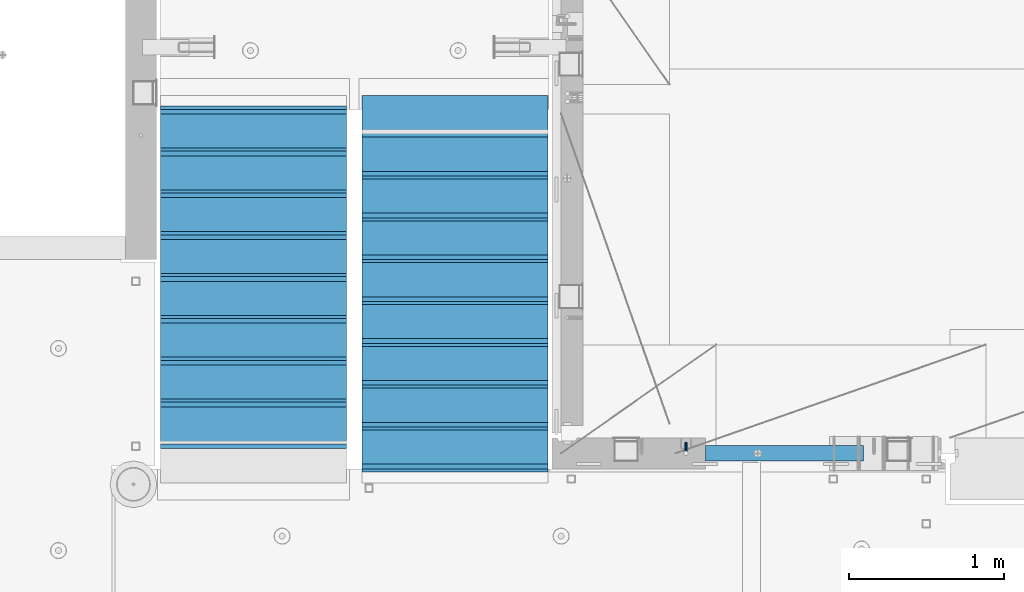
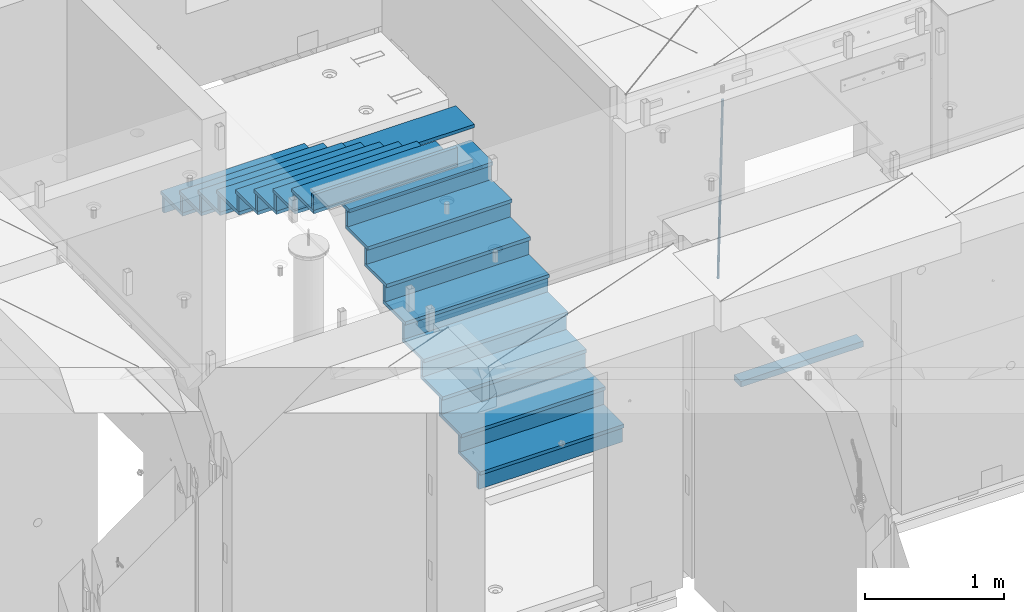
# One storey, part 118 of 352: 36 beams, 3 elements without a shape of their own.
"""IFC2X3 building model written with IfcOpenShell, lengths in millimetres."""

from ifc_helpers import new_model, si_unit, frame, origin_with_axes, place, context, subcontext, project, spatial, faceted_brep, material, type_object, element, aggregate, save


model = new_model("IFC2X3")

# Units and contexts
model_context = context("Model", 3, precision=1e-05, world=origin_with_axes())
body_context = subcontext(model_context, "Body", "Model", "MODEL_VIEW")
ifc_project = project(units=[si_unit("LENGTHUNIT", "METRE", prefix="MILLI"), si_unit("AREAUNIT", "SQUARE_METRE"), si_unit("VOLUMEUNIT", "CUBIC_METRE"), si_unit("MASSUNIT", "GRAM", prefix="KILO"), si_unit("TIMEUNIT", "SECOND"), si_unit("PLANEANGLEUNIT", "RADIAN"), si_unit("SOLIDANGLEUNIT", "STERADIAN"), si_unit("THERMODYNAMICTEMPERATUREUNIT", "DEGREE_CELSIUS"), si_unit("LUMINOUSINTENSITYUNIT", "LUMEN")], contexts=[model_context])

# Site, building, storey
site_placement = place(None, origin_with_axes())
site = spatial("IfcSite", under=ifc_project, at=site_placement, CompositionType="ELEMENT")
building_placement = place(site_placement, origin_with_axes())
building = spatial("IfcBuilding", under=site, at=building_placement, CompositionType="ELEMENT")
storey_placement = place(building_placement, origin_with_axes())
storey = spatial("IfcBuildingStorey", under=building, at=storey_placement, Name="6", CompositionType="ELEMENT", Elevation=0.0)

# Assembly, beams
assembly_1_placement = place(storey_placement, origin_with_axes())
assembly_1 = element("IfcElementAssembly", 1, at=assembly_1_placement, inside=storey, AssemblyPlace="NOTDEFINED", PredefinedType="REINFORCEMENT_UNIT")
ifc_material_1 = material()
beam_type_1 = type_object("IfcBeamType", Name="D20", PredefinedType="NOTDEFINED")
beam_1_placement = place(assembly_1_placement, frame((23075.0006866416, 17045.0000022791, 97790.0), z_axis=(0.00020576299992186, -0.999642804629538, -0.0267249099901004), x_axis=(-4.30000201928125e-08, -0.0267249099948059, 0.999642825806181)))
beam_1 = element("IfcBeam", 2, at=beam_1_placement, type_object=beam_type_1, material=ifc_material_1, Name="JM20", ObjectType="D20", context=body_context, shape_type="Brep", body=[
    faceted_brep([(0.0, -10.0, 0.0), (-4.19531716033816e-08, -7.07106781186667, -7.07106781187031), (60.4266690400545, -7.0710677960451, -7.07106780570757), (60.4266690441291, -9.99999998418934, 6.15546014159918e-09), (0.0, 0.0, -10.0), (60.426669036824, 1.58106558956206e-08, -9.99999999384454), (4.196772351861e-08, 7.07106781186303, -7.07106781186667), (60.4266690363438, 7.07106782768096, -7.07106780570757), (0.0, 10.0, 0.0), (60.4266690388904, 10.0000000158179, 6.15182216279209e-09), (4.196772351861e-08, 7.07106781185939, 7.07106781185939), (60.4266690429649, 7.07106782768096, 7.07106781802577), (0.0, 0.0, 10.0), (60.4266690461809, 1.58179318532348e-08, 10.0000000061555), (-4.19531716033816e-08, -7.07106781187031, 7.07106781185939), (60.4266690466611, -7.07106779605238, 7.07106781802213), (61.0378400410118, -7.07106779588503, -7.07106780564936), (60.991799419251, -9.99999998403655, 6.21366780251265e-09), (61.0569027789461, 1.5985278878361e-08, -9.99999999378269), (61.0378209396877, 7.07106782784831, -7.07106780564936), (60.9917724058905, 10.0000000159635, 6.21366780251265e-09), (60.9457317841297, 7.07106782781193, 7.0710678180767), (60.9266690461809, 1.59488990902901e-08, 10.0000000062028), (60.9457508854539, -7.07106779591413, 7.0710678180767), (61.6489592143771, -7.07106614513759, -7.06310863441468), (61.5568818710308, -9.9999984576425, 0.00735959856683621), (61.6870830769039, 1.71821739058942e-06, -9.99179257185824), (61.6489210170112, 7.07106947854481, -7.06310888312146), (61.556827851804, 10.0000015422847, 0.00735924683976918), (61.4647505084577, 7.07106922979438, 7.07782747982128), (61.4266266459163, 1.36643211590126e-06, 10.0065114172685), (61.464788705809, -7.07106639389531, 7.07782772852806), (176.543135720174, -7.07075579406956, -5.56673531796696), (176.451058376813, -9.99968810657447, 1.50373291501455), (176.581259582701, 0.000312069292704109, -8.49541925541052), (176.543097522794, 7.07137982961285, -5.56673556667374), (176.451004357587, 10.00031189336, 1.50373256329476), (176.35892701424, 7.07137958085514, 8.57420079627263), (176.320803151699, 0.000311717507429421, 11.5028847337162), (176.358965211621, -7.07075604281999, 8.57420104497578), (177.098753836006, -7.07075429323595, -5.55949898843028), (176.98362511232, -9.99968666800123, 1.510669025065), (177.146421932586, 0.000313595905026887, -8.48805862247536), (177.098706077581, 7.07138133041735, -5.55949936166144), (176.983557571715, 10.0003133318824, 1.51066849724157), (176.868428848029, 7.07138095712435, 8.58083651073321), (176.820760751449, 0.000313067976094317, 11.5093961447819), (176.868476606425, -7.07075466652896, 8.58083688396073), (177.654312950661, -7.07075204110879, -5.54863964998367), (177.516135294456, -9.99968450931192, 1.52107783331303), (177.711524267797, 0.000315886711177882, -8.47701274570863), (177.654255632195, 7.07138358250813, -5.54864021007961), (177.516054233929, 10.0003154905207, 1.5210770412159), (177.377876577739, 7.0713830223176, 8.59079452451624), (177.320665260588, 0.000315094497636892, 11.5191676202448), (177.377933896176, -7.07075260129932, 8.59079508461218), (299.580241614967, -7.07025777803938, -3.16539205229128), (299.442063958748, -9.99919024624614, 3.90432543100542), (299.637452932104, 0.000810149780591019, -6.09376514801625), (299.58018429653, 7.07187784557391, -3.16539261238358), (299.441982898265, 10.0008097535901, 3.90432463891557), (299.303805242045, 7.07187728538338, 10.974042122205), (299.246593924894, 0.00080935756341205, 13.9024152179336), (299.303862560482, -7.07025833822991, 10.9740426822973), (300.088882651282, -7.07025571611666, -3.15544980669438), (299.971788958996, -9.99918809853989, 3.91467979818117), (300.137357441272, 0.000812176291219657, -6.0839936725497), (300.088834180511, 7.07187990754028, -3.15545019384081), (299.971753863239, 10.0008119014747, 3.91467990454839), (299.854660170953, 7.07187951844026, 10.9848095094276), (299.806185380992, 0.000811626032373169, 13.9133533752902), (299.854708641738, -7.07025610520941, 10.9848098965813), (300.597573977022, -7.07025429077839, -3.14854421417112), (300.501599787152, -9.99918661431002, 3.92187219230618), (300.637311376035, 0.00081357714952901, -6.07720669196715), (300.597534354776, 7.07188133290401, -3.14854448120241), (300.501543752835, 10.0008133856099, 3.92187181466215), (300.40556956298, 7.07188106207104, 10.9922882211395), (300.365832163967, 0.000813194146758178, 13.9209506989318), (300.405609185211, -7.07025456160045, 10.9922884881707), (1494.60304651056, -7.06690872122999, 13.060333041718), (1494.50707232069, -9.99584104476162, 20.1307494481916), (1494.64278390956, 0.00415914670156781, 10.1316705639183), (1494.6030068883, 7.07522690244878, 13.0603327746867), (1494.50701628637, 10.004158955162, 20.1307490705476), (1494.4110420965, 7.07522663162308, 27.2011654770249), (1494.3713046975, 0.00415876370243495, 30.1298279548209), (1494.41108171875, -7.06690899205205, 27.2011657440526), (1495.1211563645, -7.06690726950183, 13.067366492749), (1495.00702625545, -9.99583964390331, 20.1375364287742), (1495.20660775043, 0.00416072652296862, 10.1393245920117), (1495.21332415029, 7.07522861253892, 13.0686179608165), (1495.13737118813, 10.0041607213934, 20.1393062718889), (1495.02324107911, 7.07522834699193, 27.2094762079141), (1494.93778969315, 0.00416035097441636, 30.1375181086514), (1494.93107329329, -7.06690753504881, 27.2082247398503), (1495.63922435709, -7.07365070849846, 13.0742491942874), (1495.5069397148, -10.00235861486, 20.1441724282631), (1495.77038591086, -0.00317370150150964, 10.1468279224828), (1495.82359171678, 7.06728286786529, 13.0767522910828), (1495.76767453534, 9.99594143344802, 20.1477123416917), (1495.63538989302, 7.0672335270865, 27.2176355756565), (1495.50422833927, -0.00324347991045215, 30.1450568474684), (1495.45102253335, -7.07370004928453, 27.2151324788683), (1517.48046966468, -7.35846502584536, 13.3649345949125), (1517.34818502239, -10.2871729322142, 20.4348578288809), (1517.61163121845, -0.287988018848409, 10.4375133231042), (1517.66483702436, 6.78246855052203, 13.3674376917079), (1517.60891984291, 9.71112711610476, 20.4383977423167), (1517.47663520063, 6.78241920973232, 27.5083209762815), (1517.34547364687, -0.288057797257352, 30.4357422480862), (1517.29226784095, -7.35851436663143, 27.5058178794898), (1518.11590717161, -7.36675126123009, 13.3733916404526), (1518.00827439407, -10.295780632965, 20.4436429663911), (1518.18994308249, -0.295529324139352, 10.4452100827657), (1518.18701289421, 6.77565927010801, 13.3743873367348), (1518.10883307132, 9.70460814510079, 20.4450510935785), (1518.00120029377, 6.77557877335857, 27.515302419517), (1517.9271643829, -0.295643163732166, 30.4434839772002), (1517.93009457119, -7.36683175797953, 27.5143067232275), (1518.75139849893, -7.36487536471395, 13.3816537936873), (1518.66841952164, -10.2938120781764, 20.4522328350286), (1518.76830418318, -0.293831718903675, 10.452712053142), (1518.7092334538, 6.77719739167878, 13.3811419616068), (1518.60878914295, 9.7060990139762, 20.4515089951637), (1518.52581016565, 6.77716230052101, 27.522088036505), (1518.50890448141, -0.293881345296541, 30.4510297770539), (1518.56797521077, -7.36491045587172, 27.5225998685855), (1618.77218426704, -7.06661321754655, 14.6790318180938), (1618.68920528975, -9.99554993101265, 21.7496108594387), (1618.78908995127, 0.0044304282637313, 11.7500900775485), (1618.73001922191, 7.07545953884255, 14.6785199860096), (1618.62957491104, 10.0043611611436, 21.748887019563), (1618.54659593375, 7.07542444768478, 28.8194660609042), (1618.52969024952, 0.00438080187086598, 31.7484078014531), (1618.58876097888, -7.06664830870795, 28.819977892992)], [[[0, 1, 2, 3]], [[1, 4, 5, 2]], [[4, 6, 7, 5]], [[6, 8, 9, 7]], [[8, 10, 11, 9]], [[10, 12, 13, 11]], [[12, 14, 15, 13]], [[14, 0, 3, 15]], [[14, 12, 10, 8, 6, 4, 1, 0]], [[3, 2, 16, 17]], [[2, 5, 18, 16]], [[5, 7, 19, 18]], [[7, 9, 20, 19]], [[9, 11, 21, 20]], [[11, 13, 22, 21]], [[13, 15, 23, 22]], [[15, 3, 17, 23]], [[17, 16, 24, 25]], [[16, 18, 26, 24]], [[18, 19, 27, 26]], [[19, 20, 28, 27]], [[20, 21, 29, 28]], [[21, 22, 30, 29]], [[22, 23, 31, 30]], [[23, 17, 25, 31]], [[25, 24, 32, 33]], [[24, 26, 34, 32]], [[26, 27, 35, 34]], [[27, 28, 36, 35]], [[28, 29, 37, 36]], [[29, 30, 38, 37]], [[30, 31, 39, 38]], [[31, 25, 33, 39]], [[33, 32, 40, 41]], [[32, 34, 42, 40]], [[34, 35, 43, 42]], [[35, 36, 44, 43]], [[36, 37, 45, 44]], [[37, 38, 46, 45]], [[38, 39, 47, 46]], [[39, 33, 41, 47]], [[41, 40, 48, 49]], [[40, 42, 50, 48]], [[42, 43, 51, 50]], [[43, 44, 52, 51]], [[44, 45, 53, 52]], [[45, 46, 54, 53]], [[46, 47, 55, 54]], [[47, 41, 49, 55]], [[49, 48, 56, 57]], [[48, 50, 58, 56]], [[50, 51, 59, 58]], [[51, 52, 60, 59]], [[52, 53, 61, 60]], [[53, 54, 62, 61]], [[54, 55, 63, 62]], [[55, 49, 57, 63]], [[57, 56, 64, 65]], [[56, 58, 66, 64]], [[58, 59, 67, 66]], [[59, 60, 68, 67]], [[60, 61, 69, 68]], [[61, 62, 70, 69]], [[62, 63, 71, 70]], [[63, 57, 65, 71]], [[65, 64, 72, 73]], [[64, 66, 74, 72]], [[66, 67, 75, 74]], [[67, 68, 76, 75]], [[68, 69, 77, 76]], [[69, 70, 78, 77]], [[70, 71, 79, 78]], [[71, 65, 73, 79]], [[73, 72, 80, 81]], [[72, 74, 82, 80]], [[74, 75, 83, 82]], [[75, 76, 84, 83]], [[76, 77, 85, 84]], [[77, 78, 86, 85]], [[78, 79, 87, 86]], [[79, 73, 81, 87]], [[81, 80, 88, 89]], [[80, 82, 90, 88]], [[82, 83, 91, 90]], [[83, 84, 92, 91]], [[84, 85, 93, 92]], [[85, 86, 94, 93]], [[86, 87, 95, 94]], [[87, 81, 89, 95]], [[89, 88, 96, 97]], [[88, 90, 98, 96]], [[90, 91, 99, 98]], [[91, 92, 100, 99]], [[92, 93, 101, 100]], [[93, 94, 102, 101]], [[94, 95, 103, 102]], [[95, 89, 97, 103]], [[97, 96, 104, 105]], [[96, 98, 106, 104]], [[98, 99, 107, 106]], [[99, 100, 108, 107]], [[100, 101, 109, 108]], [[101, 102, 110, 109]], [[102, 103, 111, 110]], [[103, 97, 105, 111]], [[105, 104, 112, 113]], [[104, 106, 114, 112]], [[106, 107, 115, 114]], [[107, 108, 116, 115]], [[108, 109, 117, 116]], [[109, 110, 118, 117]], [[110, 111, 119, 118]], [[111, 105, 113, 119]], [[113, 112, 120, 121]], [[112, 114, 122, 120]], [[114, 115, 123, 122]], [[115, 116, 124, 123]], [[116, 117, 125, 124]], [[117, 118, 126, 125]], [[118, 119, 127, 126]], [[119, 113, 121, 127]], [[121, 120, 128, 129]], [[120, 122, 130, 128]], [[122, 123, 131, 130]], [[123, 124, 132, 131]], [[124, 125, 133, 132]], [[125, 126, 134, 133]], [[126, 127, 135, 134]], [[127, 121, 129, 135]], [[130, 131, 132, 133, 134, 135, 129, 128]]]),
])
ifc_material_2 = material(Name="TIMBER/T24")
beam_type_2 = type_object("IfcBeamType", PredefinedType="NOTDEFINED")
beam_2_placement = place(assembly_1_placement, frame((23200.0006866455, 16980.0, 96880.0), z_axis=(0.0, 0.0, 1.0), x_axis=(1.0, 0.0, 0.0)))
beam_2 = element("IfcBeam", 3, at=beam_2_placement, type_object=beam_type_2, material=ifc_material_2, context=body_context, shape_type="Brep", body=[
    faceted_brep([(0.0, 50.0, -25.0), (0.0, 50.0, 25.0), (1020.0, 50.0, 25.0), (1020.0, 50.0, -25.0), (0.0, -50.0, 25.0), (1020.0, -50.0, 25.0), (0.0, -50.0, -25.0), (1020.0, -50.0, -25.0)], [[[0, 1, 2, 3]], [[1, 4, 5, 2]], [[4, 6, 7, 5]], [[6, 0, 3, 7]], [[5, 7, 3, 2]], [[6, 4, 1, 0]]]),
])
aggregate(assembly_1, [beam_1, beam_2])

assembly_2_placement = place(storey_placement, origin_with_axes())
assembly_2 = element("IfcElementAssembly", 4, at=assembly_2_placement, inside=storey, Name="E9", AssemblyPlace="NOTDEFINED", PredefinedType="NOTDEFINED")
ifc_material_3 = material(Name="Undefined/C32/40")
beam_type_3 = type_object("IfcBeamType", PredefinedType="NOTDEFINED")
beam_3_placement = place(assembly_2_placement, frame((20885.0002457424, 17024.9998138874, 99662.1), z_axis=(0.0, 1.0, 0.0), x_axis=(-1.0, 3.00000001838171e-08, 0.0)))
beam_3 = element("IfcBeam", 5, at=beam_3_placement, type_object=beam_type_3, material=ifc_material_3, Name="E9", context=body_context, shape_type="Brep", body=[
    faceted_brep([(0.0, 68.5, -15.0), (0.0, 68.5, 15.0), (1200.0, 68.5, 15.0), (1200.0, 68.5, -15.0), (0.0, -68.5, 15.0), (1200.0, -68.5, 15.0), (0.0, -68.5, -15.0), (1200.0, -68.5, -15.0)], [[[0, 1, 2, 3]], [[1, 4, 5, 2]], [[4, 6, 7, 5]], [[6, 0, 3, 7]], [[5, 7, 3, 2]], [[6, 4, 1, 0]]]),
])
beam_4_placement = place(assembly_2_placement, frame((20885.0002457424, 17294.9998138874, 99495.4), z_axis=(0.0, 1.0, 0.0), x_axis=(-1.0, 3.00000001838171e-08, 0.0)))
beam_4 = element("IfcBeam", 6, at=beam_4_placement, type_object=beam_type_3, material=ifc_material_3, Name="E9", context=body_context, shape_type="Brep", body=[
    faceted_brep([(0.0, 68.5, -15.0), (0.0, 68.5, 15.0), (1200.0, 68.5, 15.0), (1200.0, 68.5, -15.0), (0.0, -68.5, 15.0), (1200.0, -68.5, 15.0), (0.0, -68.5, -15.0), (1200.0, -68.5, -15.0)], [[[0, 1, 2, 3]], [[1, 4, 5, 2]], [[4, 6, 7, 5]], [[6, 0, 3, 7]], [[5, 7, 3, 2]], [[6, 4, 1, 0]]]),
])
beam_5_placement = place(assembly_2_placement, frame((20885.0002457424, 17564.9998138874, 99328.7), z_axis=(0.0, 1.0, 0.0), x_axis=(-1.0, 3.00000001838171e-08, 0.0)))
beam_5 = element("IfcBeam", 7, at=beam_5_placement, type_object=beam_type_3, material=ifc_material_3, Name="E9", context=body_context, shape_type="Brep", body=[
    faceted_brep([(0.0, 68.5, -15.0), (0.0, 68.5, 15.0), (1200.0, 68.5, 15.0), (1200.0, 68.5, -15.0), (0.0, -68.5, 15.0), (1200.0, -68.5, 15.0), (0.0, -68.5, -15.0), (1200.0, -68.5, -15.0)], [[[0, 1, 2, 3]], [[1, 4, 5, 2]], [[4, 6, 7, 5]], [[6, 0, 3, 7]], [[5, 7, 3, 2]], [[6, 4, 1, 0]]]),
])
beam_6_placement = place(assembly_2_placement, frame((20885.0002457424, 17834.9998138874, 99162.0), z_axis=(0.0, 1.0, 0.0), x_axis=(-1.0, 3.00000001838171e-08, 0.0)))
beam_6 = element("IfcBeam", 8, at=beam_6_placement, type_object=beam_type_3, material=ifc_material_3, Name="E9", context=body_context, shape_type="Brep", body=[
    faceted_brep([(0.0, 68.5, -15.0), (0.0, 68.5, 15.0), (1200.0, 68.5, 15.0), (1200.0, 68.5, -15.0), (0.0, -68.5, 15.0), (1200.0, -68.5, 15.0), (0.0, -68.5, -15.0), (1200.0, -68.5, -15.0)], [[[0, 1, 2, 3]], [[1, 4, 5, 2]], [[4, 6, 7, 5]], [[6, 0, 3, 7]], [[5, 7, 3, 2]], [[6, 4, 1, 0]]]),
])
beam_7_placement = place(assembly_2_placement, frame((20885.0002457424, 18104.9998138874, 98995.3), z_axis=(0.0, 1.0, 0.0), x_axis=(-1.0, 3.00000001838171e-08, 0.0)))
beam_7 = element("IfcBeam", 9, at=beam_7_placement, type_object=beam_type_3, material=ifc_material_3, Name="E9", context=body_context, shape_type="Brep", body=[
    faceted_brep([(0.0, 68.5, -15.0), (0.0, 68.5, 15.0), (1200.0, 68.5, 15.0), (1200.0, 68.5, -15.0), (0.0, -68.5, 15.0), (1200.0, -68.5, 15.0), (0.0, -68.5, -15.0), (1200.0, -68.5, -15.0)], [[[0, 1, 2, 3]], [[1, 4, 5, 2]], [[4, 6, 7, 5]], [[6, 0, 3, 7]], [[5, 7, 3, 2]], [[6, 4, 1, 0]]]),
])
beam_8_placement = place(assembly_2_placement, frame((20885.0002457424, 18374.9998138874, 98828.6), z_axis=(0.0, 1.0, 0.0), x_axis=(-1.0, 3.00000001838171e-08, 0.0)))
beam_8 = element("IfcBeam", 10, at=beam_8_placement, type_object=beam_type_3, material=ifc_material_3, Name="E9", context=body_context, shape_type="Brep", body=[
    faceted_brep([(0.0, 68.5, -15.0), (0.0, 68.5, 15.0), (1200.0, 68.5, 15.0), (1200.0, 68.5, -15.0), (0.0, -68.5, 15.0), (1200.0, -68.5, 15.0), (0.0, -68.5, -15.0), (1200.0, -68.5, -15.0)], [[[0, 1, 2, 3]], [[1, 4, 5, 2]], [[4, 6, 7, 5]], [[6, 0, 3, 7]], [[5, 7, 3, 2]], [[6, 4, 1, 0]]]),
])
beam_9_placement = place(assembly_2_placement, frame((20885.0002457424, 18644.9998138874, 98661.9), z_axis=(0.0, 1.0, 0.0), x_axis=(-1.0, 3.00000001838171e-08, 0.0)))
beam_9 = element("IfcBeam", 11, at=beam_9_placement, type_object=beam_type_3, material=ifc_material_3, Name="E9", context=body_context, shape_type="Brep", body=[
    faceted_brep([(0.0, 68.5, -15.0), (0.0, 68.5, 15.0), (1200.0, 68.5, 15.0), (1200.0, 68.5, -15.0), (0.0, -68.5, 15.0), (1200.0, -68.5, 15.0), (0.0, -68.5, -15.0), (1200.0, -68.5, -15.0)], [[[0, 1, 2, 3]], [[1, 4, 5, 2]], [[4, 6, 7, 5]], [[6, 0, 3, 7]], [[5, 7, 3, 2]], [[6, 4, 1, 0]]]),
])
beam_10_placement = place(assembly_2_placement, frame((20885.0002457424, 18914.9998138874, 98495.2), z_axis=(0.0, 1.0, 0.0), x_axis=(-1.0, 3.00000001838171e-08, 0.0)))
beam_10 = element("IfcBeam", 12, at=beam_10_placement, type_object=beam_type_3, material=ifc_material_3, Name="E9", context=body_context, shape_type="Brep", body=[
    faceted_brep([(0.0, 68.5, -15.0), (0.0, 68.5, 15.0), (1200.0, 68.5, 15.0), (1200.0, 68.5, -15.0), (0.0, -68.5, 15.0), (1200.0, -68.5, 15.0), (0.0, -68.5, -15.0), (1200.0, -68.5, -15.0)], [[[0, 1, 2, 3]], [[1, 4, 5, 2]], [[4, 6, 7, 5]], [[6, 0, 3, 7]], [[5, 7, 3, 2]], [[6, 4, 1, 0]]]),
])
beam_11_placement = place(assembly_2_placement, frame((20885.0002457424, 19184.9998138874, 98328.5), z_axis=(0.0, 1.0, 0.0), x_axis=(-1.0, 3.00000001838171e-08, 0.0)))
beam_11 = element("IfcBeam", 13, at=beam_11_placement, type_object=beam_type_3, material=ifc_material_3, Name="E9", context=body_context, shape_type="Brep", body=[
    faceted_brep([(0.0, 68.5, -15.0), (0.0, 68.5, 15.0), (1200.0, 68.5, 15.0), (1200.0, 68.5, -15.0), (0.0, -68.5, 15.0), (1200.0, -68.5, 15.0), (0.0, -68.5, -15.0), (1200.0, -68.5, -15.0)], [[[0, 1, 2, 3]], [[1, 4, 5, 2]], [[4, 6, 7, 5]], [[6, 0, 3, 7]], [[5, 7, 3, 2]], [[6, 4, 1, 0]]]),
])

assembly_3_placement = place(storey_placement, origin_with_axes())
assembly_3 = element("IfcElementAssembly", 14, at=assembly_3_placement, inside=storey, Name="E9", AssemblyPlace="NOTDEFINED", PredefinedType="NOTDEFINED")
beam_12_placement = place(assembly_3_placement, frame((20985.002175553, 18785.001025346, 97995.1036072969), z_axis=(0.0, -1.0, 0.0), x_axis=(1.0, 0.0, 0.0)))
beam_12 = element("IfcBeam", 15, at=beam_12_placement, type_object=beam_type_3, material=ifc_material_3, Name="E9", context=body_context, shape_type="Brep", body=[
    faceted_brep([(0.0, 68.5, -15.0), (0.0, 68.5, 15.0), (1200.0, 68.5, 15.0), (1200.0, 68.5, -15.0), (0.0, -68.5, 15.0), (1200.0, -68.5, 15.0), (0.0, -68.5, -15.0), (1200.0, -68.5, -15.0)], [[[0, 1, 2, 3]], [[1, 4, 5, 2]], [[4, 6, 7, 5]], [[6, 0, 3, 7]], [[5, 7, 3, 2]], [[6, 4, 1, 0]]]),
])
beam_13_placement = place(assembly_3_placement, frame((20985.002175553, 18515.001025346, 97828.4036072969), z_axis=(0.0, -1.0, 0.0), x_axis=(1.0, 0.0, 0.0)))
beam_13 = element("IfcBeam", 16, at=beam_13_placement, type_object=beam_type_3, material=ifc_material_3, Name="E9", context=body_context, shape_type="Brep", body=[
    faceted_brep([(0.0, 68.5, -15.0), (0.0, 68.5, 15.0), (1200.0, 68.5, 15.0), (1200.0, 68.5, -15.0), (0.0, -68.5, 15.0), (1200.0, -68.5, 15.0), (0.0, -68.5, -15.0), (1200.0, -68.5, -15.0)], [[[0, 1, 2, 3]], [[1, 4, 5, 2]], [[4, 6, 7, 5]], [[6, 0, 3, 7]], [[5, 7, 3, 2]], [[6, 4, 1, 0]]]),
])
beam_14_placement = place(assembly_3_placement, frame((20985.002175553, 18245.001025346, 97661.7036072969), z_axis=(0.0, -1.0, 0.0), x_axis=(1.0, 0.0, 0.0)))
beam_14 = element("IfcBeam", 17, at=beam_14_placement, type_object=beam_type_3, material=ifc_material_3, Name="E9", context=body_context, shape_type="Brep", body=[
    faceted_brep([(0.0, 68.5, -15.0), (0.0, 68.5, 15.0), (1200.0, 68.5, 15.0), (1200.0, 68.5, -15.0), (0.0, -68.5, 15.0), (1200.0, -68.5, 15.0), (0.0, -68.5, -15.0), (1200.0, -68.5, -15.0)], [[[0, 1, 2, 3]], [[1, 4, 5, 2]], [[4, 6, 7, 5]], [[6, 0, 3, 7]], [[5, 7, 3, 2]], [[6, 4, 1, 0]]]),
])
beam_15_placement = place(assembly_3_placement, frame((20985.002175553, 17975.001025346, 97495.0036072969), z_axis=(0.0, -1.0, 0.0), x_axis=(1.0, 0.0, 0.0)))
beam_15 = element("IfcBeam", 18, at=beam_15_placement, type_object=beam_type_3, material=ifc_material_3, Name="E9", context=body_context, shape_type="Brep", body=[
    faceted_brep([(0.0, 68.5, -15.0), (0.0, 68.5, 15.0), (1200.0, 68.5, 15.0), (1200.0, 68.5, -15.0), (0.0, -68.5, 15.0), (1200.0, -68.5, 15.0), (0.0, -68.5, -15.0), (1200.0, -68.5, -15.0)], [[[0, 1, 2, 3]], [[1, 4, 5, 2]], [[4, 6, 7, 5]], [[6, 0, 3, 7]], [[5, 7, 3, 2]], [[6, 4, 1, 0]]]),
])
beam_16_placement = place(assembly_3_placement, frame((20985.002175553, 17705.001025346, 97328.3036072969), z_axis=(0.0, -1.0, 0.0), x_axis=(1.0, 0.0, 0.0)))
beam_16 = element("IfcBeam", 19, at=beam_16_placement, type_object=beam_type_3, material=ifc_material_3, Name="E9", context=body_context, shape_type="Brep", body=[
    faceted_brep([(0.0, 68.5, -15.0), (0.0, 68.5, 15.0), (1200.0, 68.5, 15.0), (1200.0, 68.5, -15.0), (0.0, -68.5, 15.0), (1200.0, -68.5, 15.0), (0.0, -68.5, -15.0), (1200.0, -68.5, -15.0)], [[[0, 1, 2, 3]], [[1, 4, 5, 2]], [[4, 6, 7, 5]], [[6, 0, 3, 7]], [[5, 7, 3, 2]], [[6, 4, 1, 0]]]),
])
beam_17_placement = place(assembly_3_placement, frame((20985.002175553, 17435.001025346, 97161.6036072969), z_axis=(0.0, -1.0, 0.0), x_axis=(1.0, 0.0, 0.0)))
beam_17 = element("IfcBeam", 20, at=beam_17_placement, type_object=beam_type_3, material=ifc_material_3, Name="E9", context=body_context, shape_type="Brep", body=[
    faceted_brep([(0.0, 68.5, -15.0), (0.0, 68.5, 15.0), (1200.0, 68.5, 15.0), (1200.0, 68.5, -15.0), (0.0, -68.5, 15.0), (1200.0, -68.5, 15.0), (0.0, -68.5, -15.0), (1200.0, -68.5, -15.0)], [[[0, 1, 2, 3]], [[1, 4, 5, 2]], [[4, 6, 7, 5]], [[6, 0, 3, 7]], [[5, 7, 3, 2]], [[6, 4, 1, 0]]]),
])
beam_18_placement = place(assembly_3_placement, frame((20985.002175553, 17165.001025346, 96994.9036072969), z_axis=(0.0, -1.0, 0.0), x_axis=(1.0, 0.0, 0.0)))
beam_18 = element("IfcBeam", 21, at=beam_18_placement, type_object=beam_type_3, material=ifc_material_3, Name="E9", context=body_context, shape_type="Brep", body=[
    faceted_brep([(0.0, 68.5, -15.0), (0.0, 68.5, 15.0), (1200.0, 68.5, 15.0), (1200.0, 68.5, -15.0), (0.0, -68.5, 15.0), (1200.0, -68.5, 15.0), (0.0, -68.5, -15.0), (1200.0, -68.5, -15.0)], [[[0, 1, 2, 3]], [[1, 4, 5, 2]], [[4, 6, 7, 5]], [[6, 0, 3, 7]], [[5, 7, 3, 2]], [[6, 4, 1, 0]]]),
])
beam_19_placement = place(assembly_3_placement, frame((20985.002175553, 16895.001025346, 96828.2036072969), z_axis=(0.0, -1.0, 0.0), x_axis=(1.0, 0.0, 0.0)))
beam_19 = element("IfcBeam", 22, at=beam_19_placement, type_object=beam_type_3, material=ifc_material_3, Name="E9", context=body_context, shape_type="Brep", body=[
    faceted_brep([(0.0, 68.5, -15.0), (0.0, 68.5, 15.0), (1200.0, 68.5, 15.0), (1200.0, 68.5, -15.0), (0.0, -68.5, 15.0), (1200.0, -68.5, 15.0), (0.0, -68.5, -15.0), (1200.0, -68.5, -15.0)], [[[0, 1, 2, 3]], [[1, 4, 5, 2]], [[4, 6, 7, 5]], [[6, 0, 3, 7]], [[5, 7, 3, 2]], [[6, 4, 1, 0]]]),
])

# Beam
beam_type_4 = type_object("IfcBeamType", PredefinedType="NOTDEFINED")
beam_20_placement = place(assembly_2_placement, frame((20885.0002457424, 17169.9998138874, 99578.6), z_axis=(0.0, 1.0, 0.0), x_axis=(-1.0, 3.00000001838171e-08, 0.0)))
beam_20 = element("IfcBeam", 23, at=beam_20_placement, type_object=beam_type_4, material=ifc_material_3, Name="E9", context=body_context, shape_type="Brep", body=[
    faceted_brep([(0.0, 15.0, -160.0), (0.0, 15.0, 160.0), (1200.0, 15.0, 160.0), (1200.0, 15.0, -160.0), (0.0, -15.0, 160.0), (1200.0, -15.0, 160.0), (0.0, -15.0, -160.0), (1200.0, -15.0, -160.0)], [[[0, 1, 2, 3]], [[1, 4, 5, 2]], [[4, 6, 7, 5]], [[6, 0, 3, 7]], [[5, 7, 3, 2]], [[6, 4, 1, 0]]]),
])

beam_21_placement = place(assembly_2_placement, frame((20885.0002457424, 17439.9998138874, 99411.9), z_axis=(0.0, 1.0, 0.0), x_axis=(-1.0, 3.00000001838171e-08, 0.0)))
beam_21 = element("IfcBeam", 24, at=beam_21_placement, type_object=beam_type_4, material=ifc_material_3, Name="E9", context=body_context, shape_type="Brep", body=[
    faceted_brep([(0.0, 15.0, -160.0), (0.0, 15.0, 160.0), (1200.0, 15.0, 160.0), (1200.0, 15.0, -160.0), (0.0, -15.0, 160.0), (1200.0, -15.0, 160.0), (0.0, -15.0, -160.0), (1200.0, -15.0, -160.0)], [[[0, 1, 2, 3]], [[1, 4, 5, 2]], [[4, 6, 7, 5]], [[6, 0, 3, 7]], [[5, 7, 3, 2]], [[6, 4, 1, 0]]]),
])

beam_22_placement = place(assembly_2_placement, frame((20885.0002457424, 17709.9998138874, 99245.2), z_axis=(0.0, 1.0, 0.0), x_axis=(-1.0, 3.00000001838171e-08, 0.0)))
beam_22 = element("IfcBeam", 25, at=beam_22_placement, type_object=beam_type_4, material=ifc_material_3, Name="E9", context=body_context, shape_type="Brep", body=[
    faceted_brep([(0.0, 15.0, -160.0), (0.0, 15.0, 160.0), (1200.0, 15.0, 160.0), (1200.0, 15.0, -160.0), (0.0, -15.0, 160.0), (1200.0, -15.0, 160.0), (0.0, -15.0, -160.0), (1200.0, -15.0, -160.0)], [[[0, 1, 2, 3]], [[1, 4, 5, 2]], [[4, 6, 7, 5]], [[6, 0, 3, 7]], [[5, 7, 3, 2]], [[6, 4, 1, 0]]]),
])

beam_23_placement = place(assembly_2_placement, frame((20885.0002457424, 17979.9998138874, 99078.5), z_axis=(0.0, 1.0, 0.0), x_axis=(-1.0, 3.00000001838171e-08, 0.0)))
beam_23 = element("IfcBeam", 26, at=beam_23_placement, type_object=beam_type_4, material=ifc_material_3, Name="E9", context=body_context, shape_type="Brep", body=[
    faceted_brep([(0.0, 15.0, -160.0), (0.0, 15.0, 160.0), (1200.0, 15.0, 160.0), (1200.0, 15.0, -160.0), (0.0, -15.0, 160.0), (1200.0, -15.0, 160.0), (0.0, -15.0, -160.0), (1200.0, -15.0, -160.0)], [[[0, 1, 2, 3]], [[1, 4, 5, 2]], [[4, 6, 7, 5]], [[6, 0, 3, 7]], [[5, 7, 3, 2]], [[6, 4, 1, 0]]]),
])

beam_24_placement = place(assembly_2_placement, frame((20885.0002457424, 18249.9998138874, 98911.8), z_axis=(0.0, 1.0, 0.0), x_axis=(-1.0, 3.00000001838171e-08, 0.0)))
beam_24 = element("IfcBeam", 27, at=beam_24_placement, type_object=beam_type_4, material=ifc_material_3, Name="E9", context=body_context, shape_type="Brep", body=[
    faceted_brep([(0.0, 15.0, -160.0), (0.0, 15.0, 160.0), (1200.0, 15.0, 160.0), (1200.0, 15.0, -160.0), (0.0, -15.0, 160.0), (1200.0, -15.0, 160.0), (0.0, -15.0, -160.0), (1200.0, -15.0, -160.0)], [[[0, 1, 2, 3]], [[1, 4, 5, 2]], [[4, 6, 7, 5]], [[6, 0, 3, 7]], [[5, 7, 3, 2]], [[6, 4, 1, 0]]]),
])

beam_25_placement = place(assembly_2_placement, frame((20885.0002457424, 18519.9998138874, 98745.1), z_axis=(0.0, 1.0, 0.0), x_axis=(-1.0, 3.00000001838171e-08, 0.0)))
beam_25 = element("IfcBeam", 28, at=beam_25_placement, type_object=beam_type_4, material=ifc_material_3, Name="E9", context=body_context, shape_type="Brep", body=[
    faceted_brep([(0.0, 15.0, -160.0), (0.0, 15.0, 160.0), (1200.0, 15.0, 160.0), (1200.0, 15.0, -160.0), (0.0, -15.0, 160.0), (1200.0, -15.0, 160.0), (0.0, -15.0, -160.0), (1200.0, -15.0, -160.0)], [[[0, 1, 2, 3]], [[1, 4, 5, 2]], [[4, 6, 7, 5]], [[6, 0, 3, 7]], [[5, 7, 3, 2]], [[6, 4, 1, 0]]]),
])

beam_26_placement = place(assembly_2_placement, frame((20885.0002457424, 18789.9998138874, 98578.4), z_axis=(0.0, 1.0, 0.0), x_axis=(-1.0, 3.00000001838171e-08, 0.0)))
beam_26 = element("IfcBeam", 29, at=beam_26_placement, type_object=beam_type_4, material=ifc_material_3, Name="E9", context=body_context, shape_type="Brep", body=[
    faceted_brep([(0.0, 15.0, -160.0), (0.0, 15.0, 160.0), (1200.0, 15.0, 160.0), (1200.0, 15.0, -160.0), (0.0, -15.0, 160.0), (1200.0, -15.0, 160.0), (0.0, -15.0, -160.0), (1200.0, -15.0, -160.0)], [[[0, 1, 2, 3]], [[1, 4, 5, 2]], [[4, 6, 7, 5]], [[6, 0, 3, 7]], [[5, 7, 3, 2]], [[6, 4, 1, 0]]]),
])

beam_27_placement = place(assembly_2_placement, frame((20885.0002457424, 19059.9998138874, 98411.7), z_axis=(0.0, 1.0, 0.0), x_axis=(-1.0, 3.00000001838171e-08, 0.0)))
beam_27 = element("IfcBeam", 30, at=beam_27_placement, type_object=beam_type_4, material=ifc_material_3, Name="E9", context=body_context, shape_type="Brep", body=[
    faceted_brep([(0.0, 15.0, -160.0), (0.0, 15.0, 160.0), (1200.0, 15.0, 160.0), (1200.0, 15.0, -160.0), (0.0, -15.0, 160.0), (1200.0, -15.0, 160.0), (0.0, -15.0, -160.0), (1200.0, -15.0, -160.0)], [[[0, 1, 2, 3]], [[1, 4, 5, 2]], [[4, 6, 7, 5]], [[6, 0, 3, 7]], [[5, 7, 3, 2]], [[6, 4, 1, 0]]]),
])

aggregate(assembly_2, [beam_3, beam_20, beam_4, beam_21, beam_5, beam_22, beam_6, beam_23, beam_7, beam_24, beam_8, beam_25, beam_9, beam_26, beam_10, beam_27, beam_11])

beam_28_placement = place(assembly_3_placement, frame((20985.002175553, 18910.001025346, 98078.303607297), z_axis=(0.0, -1.0, 0.0), x_axis=(1.0, 0.0, 0.0)))
beam_28 = element("IfcBeam", 31, at=beam_28_placement, type_object=beam_type_4, material=ifc_material_3, Name="E9", context=body_context, shape_type="Brep", body=[
    faceted_brep([(0.0, 15.0, -160.0), (0.0, 15.0, 160.0), (1200.0, 15.0, 160.0), (1200.0, 15.0, -160.0), (0.0, -15.0, 160.0), (1200.0, -15.0, 160.0), (0.0, -15.0, -160.0), (1200.0, -15.0, -160.0)], [[[0, 1, 2, 3]], [[1, 4, 5, 2]], [[4, 6, 7, 5]], [[6, 0, 3, 7]], [[5, 7, 3, 2]], [[6, 4, 1, 0]]]),
])

beam_29_placement = place(assembly_3_placement, frame((20985.002175553, 18640.001025346, 97911.6036072969), z_axis=(0.0, -1.0, 0.0), x_axis=(1.0, 0.0, 0.0)))
beam_29 = element("IfcBeam", 32, at=beam_29_placement, type_object=beam_type_4, material=ifc_material_3, Name="E9", context=body_context, shape_type="Brep", body=[
    faceted_brep([(0.0, 15.0, -160.0), (0.0, 15.0, 160.0), (1200.0, 15.0, 160.0), (1200.0, 15.0, -160.0), (0.0, -15.0, 160.0), (1200.0, -15.0, 160.0), (0.0, -15.0, -160.0), (1200.0, -15.0, -160.0)], [[[0, 1, 2, 3]], [[1, 4, 5, 2]], [[4, 6, 7, 5]], [[6, 0, 3, 7]], [[5, 7, 3, 2]], [[6, 4, 1, 0]]]),
])

beam_30_placement = place(assembly_3_placement, frame((20985.002175553, 18370.001025346, 97744.9036072969), z_axis=(0.0, -1.0, 0.0), x_axis=(1.0, 0.0, 0.0)))
beam_30 = element("IfcBeam", 33, at=beam_30_placement, type_object=beam_type_4, material=ifc_material_3, Name="E9", context=body_context, shape_type="Brep", body=[
    faceted_brep([(0.0, 15.0, -160.0), (0.0, 15.0, 160.0), (1200.0, 15.0, 160.0), (1200.0, 15.0, -160.0), (0.0, -15.0, 160.0), (1200.0, -15.0, 160.0), (0.0, -15.0, -160.0), (1200.0, -15.0, -160.0)], [[[0, 1, 2, 3]], [[1, 4, 5, 2]], [[4, 6, 7, 5]], [[6, 0, 3, 7]], [[5, 7, 3, 2]], [[6, 4, 1, 0]]]),
])

beam_31_placement = place(assembly_3_placement, frame((20985.002175553, 18100.001025346, 97578.2036072969), z_axis=(0.0, -1.0, 0.0), x_axis=(1.0, 0.0, 0.0)))
beam_31 = element("IfcBeam", 34, at=beam_31_placement, type_object=beam_type_4, material=ifc_material_3, Name="E9", context=body_context, shape_type="Brep", body=[
    faceted_brep([(0.0, 15.0, -160.0), (0.0, 15.0, 160.0), (1200.0, 15.0, 160.0), (1200.0, 15.0, -160.0), (0.0, -15.0, 160.0), (1200.0, -15.0, 160.0), (0.0, -15.0, -160.0), (1200.0, -15.0, -160.0)], [[[0, 1, 2, 3]], [[1, 4, 5, 2]], [[4, 6, 7, 5]], [[6, 0, 3, 7]], [[5, 7, 3, 2]], [[6, 4, 1, 0]]]),
])

beam_32_placement = place(assembly_3_placement, frame((20985.002175553, 17830.001025346, 97411.5036072969), z_axis=(0.0, -1.0, 0.0), x_axis=(1.0, 0.0, 0.0)))
beam_32 = element("IfcBeam", 35, at=beam_32_placement, type_object=beam_type_4, material=ifc_material_3, Name="E9", context=body_context, shape_type="Brep", body=[
    faceted_brep([(0.0, 15.0, -160.0), (0.0, 15.0, 160.0), (1200.0, 15.0, 160.0), (1200.0, 15.0, -160.0), (0.0, -15.0, 160.0), (1200.0, -15.0, 160.0), (0.0, -15.0, -160.0), (1200.0, -15.0, -160.0)], [[[0, 1, 2, 3]], [[1, 4, 5, 2]], [[4, 6, 7, 5]], [[6, 0, 3, 7]], [[5, 7, 3, 2]], [[6, 4, 1, 0]]]),
])

beam_33_placement = place(assembly_3_placement, frame((20985.002175553, 17560.001025346, 97244.8036072969), z_axis=(0.0, -1.0, 0.0), x_axis=(1.0, 0.0, 0.0)))
beam_33 = element("IfcBeam", 36, at=beam_33_placement, type_object=beam_type_4, material=ifc_material_3, Name="E9", context=body_context, shape_type="Brep", body=[
    faceted_brep([(0.0, 15.0, -160.0), (0.0, 15.0, 160.0), (1200.0, 15.0, 160.0), (1200.0, 15.0, -160.0), (0.0, -15.0, 160.0), (1200.0, -15.0, 160.0), (0.0, -15.0, -160.0), (1200.0, -15.0, -160.0)], [[[0, 1, 2, 3]], [[1, 4, 5, 2]], [[4, 6, 7, 5]], [[6, 0, 3, 7]], [[5, 7, 3, 2]], [[6, 4, 1, 0]]]),
])

beam_34_placement = place(assembly_3_placement, frame((20985.002175553, 17290.001025346, 97078.1036072969), z_axis=(0.0, -1.0, 0.0), x_axis=(1.0, 0.0, 0.0)))
beam_34 = element("IfcBeam", 37, at=beam_34_placement, type_object=beam_type_4, material=ifc_material_3, Name="E9", context=body_context, shape_type="Brep", body=[
    faceted_brep([(0.0, 15.0, -160.0), (0.0, 15.0, 160.0), (1200.0, 15.0, 160.0), (1200.0, 15.0, -160.0), (0.0, -15.0, 160.0), (1200.0, -15.0, 160.0), (0.0, -15.0, -160.0), (1200.0, -15.0, -160.0)], [[[0, 1, 2, 3]], [[1, 4, 5, 2]], [[4, 6, 7, 5]], [[6, 0, 3, 7]], [[5, 7, 3, 2]], [[6, 4, 1, 0]]]),
])

beam_35_placement = place(assembly_3_placement, frame((20985.002175553, 17020.001025346, 96911.4036072969), z_axis=(0.0, -1.0, 0.0), x_axis=(1.0, 0.0, 0.0)))
beam_35 = element("IfcBeam", 38, at=beam_35_placement, type_object=beam_type_4, material=ifc_material_3, Name="E9", context=body_context, shape_type="Brep", body=[
    faceted_brep([(0.0, 15.0, -160.0), (0.0, 15.0, 160.0), (1200.0, 15.0, 160.0), (1200.0, 15.0, -160.0), (0.0, -15.0, 160.0), (1200.0, -15.0, 160.0), (0.0, -15.0, -160.0), (1200.0, -15.0, -160.0)], [[[0, 1, 2, 3]], [[1, 4, 5, 2]], [[4, 6, 7, 5]], [[6, 0, 3, 7]], [[5, 7, 3, 2]], [[6, 4, 1, 0]]]),
])

beam_type_5 = type_object("IfcBeamType", PredefinedType="NOTDEFINED")
beam_36_placement = place(assembly_3_placement, frame((20985.002175553, 19155.001025346, 98245.003607297), z_axis=(0.0, -1.0, 0.0), x_axis=(1.0, 0.0, 0.0)))
beam_36 = element("IfcBeam", 39, at=beam_36_placement, type_object=beam_type_5, material=ifc_material_3, Name="E9", context=body_context, shape_type="Brep", body=[
    faceted_brep([(0.0, 15.0, -135.0), (0.0, 15.0, 135.0), (1200.0, 15.0, 135.0), (1200.0, 15.0, -135.0), (0.0, -15.0, 135.0), (1200.0, -15.0, 135.0), (0.0, -15.0, -135.0), (1200.0, -15.0, -135.0)], [[[0, 1, 2, 3]], [[1, 4, 5, 2]], [[4, 6, 7, 5]], [[6, 0, 3, 7]], [[5, 7, 3, 2]], [[6, 4, 1, 0]]]),
])

aggregate(assembly_3, [beam_28, beam_12, beam_29, beam_13, beam_30, beam_14, beam_31, beam_15, beam_32, beam_16, beam_33, beam_17, beam_34, beam_18, beam_35, beam_36, beam_19])

save(model, "model.ifc")
